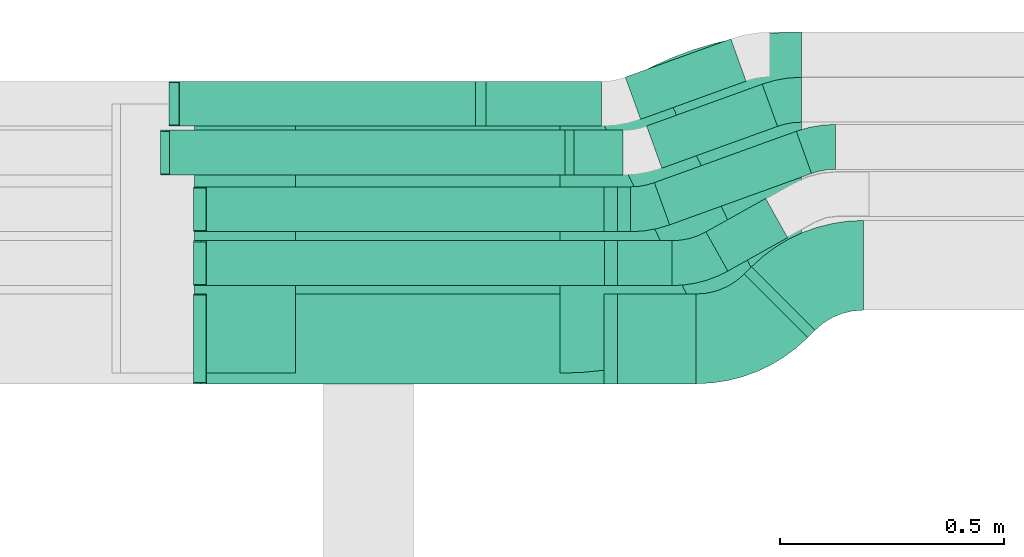
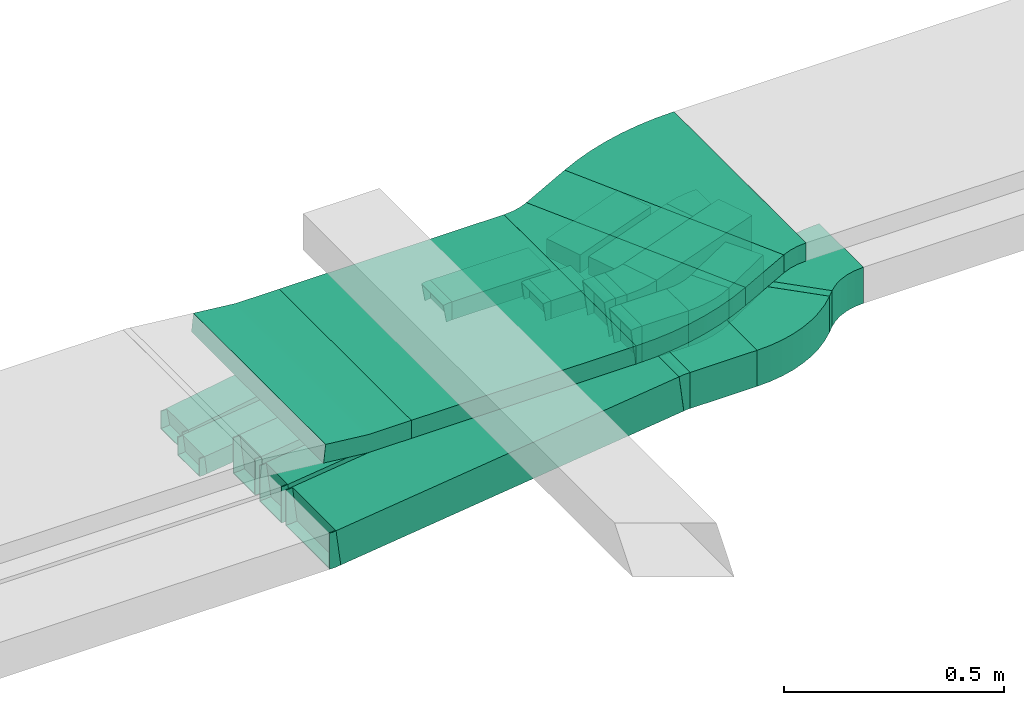
# One storey, part 18 of 28: 19 flow fittings, 17 flow segments.
"""IFC2X3 building model written with IfcOpenShell, lengths in millimetres."""

import ifcopenshell
import ifcopenshell.guid

model = None  # the IFC model being written
_history = None  # IfcOwnerHistory: only IFC2X3 demands one
_inside = {}  # id of a spatial element -> (the spatial element, [elements in it])
_under = {}  # id of a project, library or spatial element -> (it, [spatial elements below it])
_declared = {}  # id of a project -> (the project, [libraries it declares])
_typed = {}  # id of a type object -> (the type object, [elements of that type])
_made_of = {}  # id of a material, layer set ... -> (it, [elements and type objects made of it])


def new_model(schema):
    """Start an empty IFC model of exactly this schema.

    Asked for "IFC4X3", IfcOpenShell would pick the latest addendum, in which some entities
    have other attributes; the version numbers below select the first issue.
    IFC2X3 requires an IfcOwnerHistory on every rooted entity: one is made here for all.
    """
    global model, _history
    if schema == "IFC4X3":
        model = ifcopenshell.file(schema_version=(4, 3, 0, 0))
    else:
        model = ifcopenshell.file(schema=schema)
    _inside.clear()
    _under.clear()
    _declared.clear()
    _typed.clear()
    _made_of.clear()
    _history = None
    if model.schema == "IFC2X3":
        org = make("IfcOrganization", Name="unknown")
        user = make(
            "IfcPersonAndOrganization",
            ThePerson=make("IfcPerson", FamilyName="unknown"),
            TheOrganization=org,
        )
        app = make(
            "IfcApplication",
            ApplicationDeveloper=org,
            Version="unknown",
            ApplicationFullName="unknown",
            ApplicationIdentifier="unknown",
        )
        _history = make(
            "IfcOwnerHistory",
            OwningUser=user,
            OwningApplication=app,
            ChangeAction="ADDED",
            CreationDate=0,
        )
    return model


def make(cls, **values):
    """One entity of the class cls with the attributes given. An attribute that is None is left unset."""
    return model.create_entity(
        cls, **{name: value for name, value in values.items() if value is not None}
    )


def entity(cls, *values):
    """Any entity or typed value of the class cls, its attributes in the order of the schema. None: left unset."""
    e = model.create_entity(cls)
    for i, value in enumerate(values):
        if value is not None:
            e[i] = value
    return e


def rooted(cls, **values):
    """An entity with a GlobalId (a new one), such as an element, a storey or a relation."""
    return make(cls, GlobalId=ifcopenshell.guid.new(), OwnerHistory=_history, **values)


def si_unit(unit_type, name, prefix=None):
    """IfcSIUnit, for example si_unit("LENGTHUNIT", "METRE", prefix="MILLI")."""
    return make("IfcSIUnit", UnitType=unit_type, Prefix=prefix, Name=name)


def converted_unit(unit_type, name, factor, base, dimensions=None, offset=None):
    """IfcConversionBasedUnit, such as the inch: factor (a typed value) times the base unit."""
    return make(
        "IfcConversionBasedUnit"
        if offset is None
        else "IfcConversionBasedUnitWithOffset",
        ConversionOffset=offset,
        Dimensions=None
        if dimensions is None
        else entity("IfcDimensionalExponents", *dimensions),
        UnitType=unit_type,
        Name=name,
        ConversionFactor=make(
            "IfcMeasureWithUnit", ValueComponent=factor, UnitComponent=base
        ),
    )


def derived_unit(unit_type, elements):
    """IfcDerivedUnit: a product of units, each with its exponent."""
    return make(
        "IfcDerivedUnit",
        Elements=[
            make("IfcDerivedUnitElement", Unit=unit, Exponent=power)
            for unit, power in elements
        ],
        UnitType=unit_type,
    )


def assignment(units):
    """IfcUnitAssignment: the units of a project."""
    return None if units is None else make("IfcUnitAssignment", Units=units)


def point(xyz):
    """IfcCartesianPoint."""
    return None if xyz is None else make("IfcCartesianPoint", Coordinates=xyz)


def direction(xyz):
    """IfcDirection."""
    return None if xyz is None else make("IfcDirection", DirectionRatios=xyz)


def frame(location, z_axis=None, x_axis=None):
    """IfcAxis2Placement3D, a coordinate frame: its origin and axes. An axis left out is left unset."""
    return make(
        "IfcAxis2Placement3D",
        Location=point(location),
        Axis=direction(z_axis),
        RefDirection=direction(x_axis),
    )


def frame_2d(location, x_axis=None):
    """IfcAxis2Placement2D, a coordinate frame in the plane: its origin and x axis."""
    return make(
        "IfcAxis2Placement2D", Location=point(location), RefDirection=direction(x_axis)
    )


def origin():
    """The frame at (0, 0, 0) with its axes left unset."""
    return frame((0.0, 0.0, 0.0))


def origin_2d_with_axis():
    """The frame at (0, 0) in the plane with the x axis (1, 0) written out."""
    return frame_2d((0.0, 0.0), x_axis=(1.0, 0.0))


def place(relative_to, where):
    """IfcLocalPlacement: puts the frame where relative to a parent placement (None: the world)."""
    return make(
        "IfcLocalPlacement", PlacementRelTo=relative_to, RelativePlacement=where
    )


def context(
    kind, dimensions, precision=None, world=None, true_north=None, identifier=None
):
    """IfcGeometricRepresentationContext, for example the 3D "Model" context."""
    return make(
        "IfcGeometricRepresentationContext",
        ContextIdentifier=identifier,
        ContextType=kind,
        CoordinateSpaceDimension=dimensions,
        Precision=precision,
        WorldCoordinateSystem=world,
        TrueNorth=true_north,
    )


def subcontext(parent, identifier, kind, view, scale=None):
    """IfcGeometricRepresentationSubContext, for example "Body" below "Model"."""
    return make(
        "IfcGeometricRepresentationSubContext",
        ContextIdentifier=identifier,
        ContextType=kind,
        ParentContext=parent,
        TargetScale=scale,
        TargetView=view,
    )


def project(units=None, contexts=None):
    """IfcProject with its units and contexts."""
    return rooted(
        "IfcProject",
        Name="project",
        RepresentationContexts=contexts,
        UnitsInContext=assignment(units),
    )


def spatial(cls, under=None, at=None, **own):
    """A site, building, storey or space (cls), placed at a placement, below another one or the project."""
    s = rooted(cls, ObjectPlacement=at, **own)
    if under is not None:
        _under.setdefault(under.id(), (under, []))[1].append(s)
    return s


def polyline(points):
    """IfcPolyline through the points."""
    return make("IfcPolyline", Points=[point(p) for p in points])


def circle_curve(where, radius):
    """IfcCircle in the frame where."""
    return make("IfcCircle", Position=where, Radius=radius)


def parameter(value):
    """IfcParameterValue: where a trimmed curve begins or ends, as a parameter of its basis curve."""
    return model.create_entity("IfcParameterValue", value)


def trimmed(basis, trim1, trim2, sense, master):
    """IfcTrimmedCurve: the piece of a basis curve between two trims."""
    return make(
        "IfcTrimmedCurve",
        BasisCurve=basis,
        Trim1=trim1,
        Trim2=trim2,
        SenseAgreement=sense,
        MasterRepresentation=master,
    )


def segment(curve, same_sense, transition):
    """IfcCompositeCurveSegment."""
    return make(
        "IfcCompositeCurveSegment",
        Transition=transition,
        SameSense=same_sense,
        ParentCurve=curve,
    )


def composite_curve(segments, self_intersect=None):
    """IfcCompositeCurve: segments joined end to end."""
    return make("IfcCompositeCurve", Segments=segments, SelfIntersect=self_intersect)


def profile(cls, at=None, kind="AREA", **sizes):
    """A parametric profile (cls). Its sizes go by their IFC names, for example OverallWidth=200.0."""
    return make(cls, ProfileType=kind, Position=at, **sizes)


def rectangle(**sizes):
    """IfcRectangleProfileDef."""
    return profile("IfcRectangleProfileDef", **sizes)


def outline(outer, holes=None, kind="AREA"):
    """IfcArbitraryClosedProfileDef: a profile drawn as a closed curve; with holes, ...WithVoids."""
    if holes is None:
        return make("IfcArbitraryClosedProfileDef", ProfileType=kind, OuterCurve=outer)
    return make(
        "IfcArbitraryProfileDefWithVoids",
        ProfileType=kind,
        OuterCurve=outer,
        InnerCurves=holes,
    )


def extrude(swept, where, along, depth):
    """IfcExtrudedAreaSolid: the profile swept, set in the frame where, extruded along a direction by depth."""
    return make(
        "IfcExtrudedAreaSolid",
        SweptArea=swept,
        Position=where,
        ExtrudedDirection=direction(along),
        Depth=depth,
    )


def faces_of(points, faces, orient=None, outer=None):
    """IfcFace entities. A face is a list of loops; a loop is a list of indices into points, from 0.

    orient and outer hold one flag for each loop. By default every Orientation is true, the
    first loop of a face is its IfcFaceOuterBound and the others are IfcFaceBound.
    """
    made = []
    for i, loops in enumerate(faces):
        bounds = []
        for j, loop in enumerate(loops):
            is_outer = j == 0 if outer is None else outer[i][j]
            bounds.append(
                make(
                    "IfcFaceOuterBound" if is_outer else "IfcFaceBound",
                    Bound=make("IfcPolyLoop", Polygon=[points[k] for k in loop]),
                    Orientation=True if orient is None else orient[i][j],
                )
            )
        made.append(make("IfcFace", Bounds=bounds))
    return made


def faceted_brep(points, faces, orient=None, outer=None, voids=None):
    """IfcFacetedBrep: a solid bounded by flat faces; with voids (closed shells), ...WithVoids."""
    shared = [point(p) for p in points]
    hull = make("IfcClosedShell", CfsFaces=faces_of(shared, faces, orient, outer))
    if voids is None:
        return make("IfcFacetedBrep", Outer=hull)
    return make(
        "IfcFacetedBrepWithVoids",
        Outer=hull,
        Voids=[
            make(cls, CfsFaces=faces_of(shared, fs, o, b)) for cls, fs, o, b in voids
        ],
    )


def shape(context_of_items, identifier, shape_type, items):
    """IfcShapeRepresentation: the items that make up one representation, for example the "Body"."""
    return make(
        "IfcShapeRepresentation",
        ContextOfItems=context_of_items,
        RepresentationIdentifier=identifier,
        RepresentationType=shape_type,
        Items=items,
    )


def source(mapping_origin, context_of_items, identifier, shape_type, items):
    """IfcRepresentationMap: a shape defined once, which mapped items show again and again."""
    return make(
        "IfcRepresentationMap",
        MappingOrigin=mapping_origin,
        MappedRepresentation=shape(context_of_items, identifier, shape_type, items),
    )


def transform(
    local_origin,
    x_axis=None,
    y_axis=None,
    z_axis=None,
    scale=None,
    scale2=None,
    scale3=None,
    uniform=True,
):
    """IfcCartesianTransformationOperator3D, or its non-uniform kind. x_axis, y_axis, z_axis: its Axis1, 2, 3."""
    if uniform:
        return make(
            "IfcCartesianTransformationOperator3D",
            Axis1=direction(x_axis),
            Axis2=direction(y_axis),
            LocalOrigin=point(local_origin),
            Scale=scale,
            Axis3=direction(z_axis),
        )
    return make(
        "IfcCartesianTransformationOperator3DnonUniform",
        Axis1=direction(x_axis),
        Axis2=direction(y_axis),
        LocalOrigin=point(local_origin),
        Scale=scale,
        Axis3=direction(z_axis),
        Scale2=scale2,
        Scale3=scale3,
    )


def mapped(mapping_source, mapping_target):
    """IfcMappedItem: shows the shape of a source again, moved by a transform."""
    return make(
        "IfcMappedItem", MappingSource=mapping_source, MappingTarget=mapping_target
    )


def material(Name=None, Category=None):
    """IfcMaterial."""
    return make("IfcMaterial", Name=Name, Category=Category)


def made_of(thing, what):
    """Note that an element or type object is made of a material, layer set ...; save() writes the relation."""
    if what is not None:
        _made_of.setdefault(what.id(), (what, []))[1].append(thing)
    return thing


def type_object(cls, material=None, **own):
    """A type object (cls), such as IfcWallType, which elements share."""
    return made_of(rooted(cls, **own), material)


def type_shapes(of_type, sources):
    """Give a type object the sources (RepresentationMaps) that its elements show as mapped items."""
    of_type.RepresentationMaps = sources


def element(
    cls,
    number,
    at=None,
    inside=None,
    cuts=None,
    type_object=None,
    material=None,
    context=None,
    identifier="Body",
    shape_type=None,
    held_by="IfcProductDefinitionShape",
    body=None,
    shapes=None,
    **own,
):
    """One element of the class cls, such as IfcWall. Its Tag is "e" and its number.

    at: its placement. inside: the storey or other place that contains it. cuts: it is an
    opening in that element (IfcRelVoidsElement). A single representation is given by context,
    identifier, shape_type and body (its items); several are given by shapes. held_by: the class
    of the entity that holds the representations. save() writes the other relations.
    """
    e = rooted(cls, Tag="e%d" % number, ObjectPlacement=at, **own)
    if body is not None:
        shapes = [shape(context, identifier, shape_type, body)]
    if shapes is not None:
        e.Representation = make(held_by, Representations=shapes)
    if inside is not None:
        _inside.setdefault(inside.id(), (inside, []))[1].append(e)
    if cuts is not None:
        rooted(
            "IfcRelVoidsElement", RelatingBuildingElement=cuts, RelatedOpeningElement=e
        )
    if type_object is not None:
        _typed.setdefault(type_object.id(), (type_object, []))[1].append(e)
    return made_of(e, material)


def aggregate(whole, parts):
    """IfcRelAggregates: a whole, such as a stair, and the parts it consists of."""
    return rooted("IfcRelAggregates", RelatingObject=whole, RelatedObjects=parts)


def save(model, path):
    """Write the relations noted so far, then the file.

    IfcRelAggregates (storeys below a building ...), IfcRelContainedInSpatialStructure (elements
    in a storey), IfcRelDefinesByType, IfcRelAssociatesMaterial and IfcRelDeclares: one each for
    every whole, place, type object, material and project.
    """
    for whole, parts in _under.values():
        aggregate(whole, parts)
    for where, things in _inside.values():
        rooted(
            "IfcRelContainedInSpatialStructure",
            RelatedElements=things,
            RelatingStructure=where,
        )
    for kind, things in _typed.values():
        rooted("IfcRelDefinesByType", RelatedObjects=things, RelatingType=kind)
    for what, things in _made_of.values():
        rooted("IfcRelAssociatesMaterial", RelatedObjects=things, RelatingMaterial=what)
    for by, libraries in _declared.values():
        rooted("IfcRelDeclares", RelatingContext=by, RelatedDefinitions=libraries)
    model.write(path)


model = new_model("IFC2X3")

# Units and contexts
model_context = context("Model", 3, precision=0.01, world=origin(), true_north=direction((6.12303176911189e-17, 1.0)))
body_context = subcontext(model_context, "Body", "Model", "MODEL_VIEW")
ifc_project = project(units=[si_unit("LENGTHUNIT", "METRE", prefix="MILLI"), si_unit("AREAUNIT", "SQUARE_METRE"), si_unit("VOLUMEUNIT", "CUBIC_METRE"), converted_unit("PLANEANGLEUNIT", "DEGREE", entity("IfcRatioMeasure", 0.0174532925199433), si_unit("PLANEANGLEUNIT", "RADIAN"), dimensions=[0, 0, 0, 0, 0, 0, 0]), si_unit("MASSUNIT", "GRAM", prefix="KILO"), derived_unit("MASSDENSITYUNIT", [(si_unit("MASSUNIT", "GRAM", prefix="KILO"), 1), (si_unit("LENGTHUNIT", "METRE"), -3)]), derived_unit("MOMENTOFINERTIAUNIT", [(si_unit("LENGTHUNIT", "METRE"), 4)]), si_unit("TIMEUNIT", "SECOND"), si_unit("FREQUENCYUNIT", "HERTZ"), si_unit("THERMODYNAMICTEMPERATUREUNIT", "DEGREE_CELSIUS"), derived_unit("THERMALTRANSMITTANCEUNIT", [(si_unit("MASSUNIT", "GRAM", prefix="KILO"), 1), (si_unit("THERMODYNAMICTEMPERATUREUNIT", "KELVIN"), -1), (si_unit("TIMEUNIT", "SECOND"), -3)]), derived_unit("VOLUMETRICFLOWRATEUNIT", [(si_unit("LENGTHUNIT", "METRE"), 3), (si_unit("TIMEUNIT", "SECOND"), -1)]), derived_unit("MASSFLOWRATEUNIT", [(si_unit("MASSUNIT", "GRAM", prefix="KILO"), 1), (si_unit("TIMEUNIT", "SECOND"), -1)]), derived_unit("ROTATIONALFREQUENCYUNIT", [(si_unit("TIMEUNIT", "SECOND"), -1)]), si_unit("ELECTRICCURRENTUNIT", "AMPERE"), si_unit("ELECTRICVOLTAGEUNIT", "VOLT"), si_unit("POWERUNIT", "WATT"), si_unit("FORCEUNIT", "NEWTON", prefix="KILO"), si_unit("ILLUMINANCEUNIT", "LUX"), si_unit("LUMINOUSFLUXUNIT", "LUMEN"), si_unit("LUMINOUSINTENSITYUNIT", "CANDELA"), derived_unit("USERDEFINED", [(si_unit("MASSUNIT", "GRAM", prefix="KILO"), -1), (si_unit("LENGTHUNIT", "METRE"), -2), (si_unit("TIMEUNIT", "SECOND"), 3), (si_unit("LUMINOUSFLUXUNIT", "LUMEN"), 1)]), derived_unit("LINEARVELOCITYUNIT", [(si_unit("LENGTHUNIT", "METRE"), 1), (si_unit("TIMEUNIT", "SECOND"), -1)]), si_unit("PRESSUREUNIT", "PASCAL"), derived_unit("USERDEFINED", [(si_unit("LENGTHUNIT", "METRE"), -2), (si_unit("MASSUNIT", "GRAM", prefix="KILO"), 1), (si_unit("TIMEUNIT", "SECOND"), -2)]), derived_unit("LINEARFORCEUNIT", [(si_unit("MASSUNIT", "GRAM", prefix="KILO"), 1), (si_unit("LENGTHUNIT", "METRE"), 1), (si_unit("TIMEUNIT", "SECOND"), -2), (si_unit("LENGTHUNIT", "METRE"), -1)]), derived_unit("PLANARFORCEUNIT", [(si_unit("MASSUNIT", "GRAM", prefix="KILO"), 1), (si_unit("LENGTHUNIT", "METRE"), 1), (si_unit("TIMEUNIT", "SECOND"), -2), (si_unit("LENGTHUNIT", "METRE"), -2)])], contexts=[model_context])

# Site, building, storey
site_placement = place(None, origin())
site = spatial("IfcSite", under=ifc_project, at=site_placement, CompositionType="ELEMENT")
building_placement = place(site_placement, origin())
building = spatial("IfcBuilding", under=site, at=building_placement, CompositionType="ELEMENT")
storey_placement = place(building_placement, frame((0.0, 0.0, 4200.0)))
storey = spatial("IfcBuildingStorey", under=building, at=storey_placement, CompositionType="ELEMENT", Elevation=4200.0)

# Flow segments
cable_carrier_segment_type = type_object("IfcCableCarrierSegmentType", PredefinedType="CABLETRAYSEGMENT")
flow_segment_1_placement = place(storey_placement, frame((26151.95, 15455.69, 2793.21)))
element("IfcFlowSegment", 1, at=flow_segment_1_placement, inside=storey, type_object=cable_carrier_segment_type, context=body_context, shape_type="SweptSolid", body=[
    extrude(rectangle(XDim=155.206153219677, YDim=600.0, at=origin_2d_with_axis()), frame((201.26, 303.66, 0.0), z_axis=(0.0, 0.0, 1.0), x_axis=(-0.898794046299167, -0.438371146789078, 0.0)), (0.0, 0.0, 1.0), 49.9999999999995),
])
flow_segment_2_placement = place(storey_placement, frame((25495.24, 15379.35, 2793.21)))
element("IfcFlowSegment", 2, at=flow_segment_2_placement, inside=storey, type_object=cable_carrier_segment_type, context=body_context, shape_type="SweptSolid", body=[
    extrude(rectangle(XDim=589.05051708577, YDim=599.999999999998, at=origin_2d_with_axis()), frame((294.53, 300.0, 0.0), z_axis=(0.0, 0.0, 1.0), x_axis=(-1.0, 0.0, 0.0)), (0.0, 0.0, 1.0), 49.9999999999995),
])
flow_segment_3_placement = place(storey_placement, frame((26495.49, 15458.88, 2639.21)))
element("IfcFlowSegment", 3, at=flow_segment_3_placement, inside=storey, type_object=cable_carrier_segment_type, context=body_context, shape_type="SweptSolid", body=[
    extrude(rectangle(XDim=22.5844049492806, YDim=199.999999999995, at=origin_2d_with_axis()), frame((78.7, 78.7, 0.0), z_axis=(0.0, 0.0, 1.0), x_axis=(-0.707106781186596, -0.7071067811865, 0.0)), (0.0, 0.0, 1.0), 99.9999999999989),
])
flow_segment_4_placement = place(storey_placement, frame((26212.27, 15355.66, 2639.21)))
element("IfcFlowSegment", 4, at=flow_segment_4_placement, inside=storey, type_object=cable_carrier_segment_type, context=body_context, shape_type="SweptSolid", body=[
    extrude(rectangle(XDim=175.445612052065, YDim=200.000000000002, at=origin_2d_with_axis()), frame((87.72, 100.0, 0.0), z_axis=(0.0, 0.0, 1.0), x_axis=(-1.0, 0.0, 0.0)), (0.0, 0.0, 1.0), 99.9999999999989),
])
flow_segment_5_placement = place(storey_placement, frame((25284.24, 15355.66, 2526.3)))
element("IfcFlowSegment", 5, at=flow_segment_5_placement, inside=storey, type_object=cable_carrier_segment_type, context=body_context, shape_type="SweptSolid", body=[
    extrude(rectangle(XDim=99.9999999999987, YDim=200.000000000002, at=frame_2d((0.0, 0.0), x_axis=(0.0, 1.0))), frame((6.17, 100.0, 49.62), z_axis=(0.992344783104405, 0.0, 0.123498305435627), x_axis=(0.0, 1.0, 0.0)), (0.0, 0.0, 1.0), 905.864321564183),
])
flow_segment_6_placement = place(storey_placement, frame((26212.8, 15574.48, 2634.95)))
element("IfcFlowSegment", 6, at=flow_segment_6_placement, inside=storey, type_object=cable_carrier_segment_type, context=body_context, shape_type="SweptSolid", body=[
    extrude(rectangle(XDim=121.812997004483, YDim=99.9999999999989, at=origin_2d_with_axis()), frame((60.91, 50.0, 0.0), z_axis=(0.0, 0.0, 1.0), x_axis=(-1.0, 0.0, 0.0)), (0.0, 0.0, 1.0), 99.9999999999989),
])
flow_segment_7_placement = place(storey_placement, frame((25284.24, 15574.48, 2521.97)))
element("IfcFlowSegment", 7, at=flow_segment_7_placement, inside=storey, type_object=cable_carrier_segment_type, context=body_context, shape_type="SweptSolid", body=[
    extrude(rectangle(XDim=99.9999999999987, YDim=99.9999999999989, at=frame_2d((0.0, 0.0), x_axis=(0.0, 1.0))), frame((6.17, 50.0, 49.62), z_axis=(0.992344783104405, 0.0, 0.123498305435627), x_axis=(0.0, 1.0, 0.0)), (0.0, 0.0, 1.0), 906.398619593453),
])
flow_segment_8_placement = place(storey_placement, frame((26409.68, 15606.74, 2634.95)))
element("IfcFlowSegment", 8, at=flow_segment_8_placement, inside=storey, type_object=cable_carrier_segment_type, context=body_context, shape_type="SweptSolid", body=[
    extrude(rectangle(XDim=152.623669799457, YDim=99.9999999999999, at=origin_2d_with_axis()), frame((91.01, 80.88, 0.0), z_axis=(0.0, 0.0, 1.0), x_axis=(0.87289325109934, 0.487911233919884, 0.0)), (0.0, 0.0, 1.0), 99.9999999999989),
])
flow_segment_9_placement = place(storey_placement, frame((26212.27, 15694.48, 2639.21)))
element("IfcFlowSegment", 9, at=flow_segment_9_placement, inside=storey, type_object=cable_carrier_segment_type, context=body_context, shape_type="SweptSolid", body=[
    extrude(rectangle(XDim=29.5976142987202, YDim=99.9999999999989, at=origin_2d_with_axis()), frame((14.8, 50.0, 0.0), z_axis=(0.0, 0.0, 1.0), x_axis=(-1.0, 0.0, 0.0)), (0.0, 0.0, 1.0), 99.9999999999989),
])
flow_segment_10_placement = place(storey_placement, frame((25284.24, 15694.48, 2526.3)))
element("IfcFlowSegment", 10, at=flow_segment_10_placement, inside=storey, type_object=cable_carrier_segment_type, context=body_context, shape_type="SweptSolid", body=[
    extrude(rectangle(XDim=100.000000000001, YDim=99.9999999999989, at=frame_2d((0.0, 0.0), x_axis=(0.0, 1.0))), frame((6.17, 50.0, 49.62), z_axis=(0.992344783104405, 0.0, 0.123498305435624), x_axis=(0.0, 1.0, 0.0)), (0.0, 0.0, 1.0), 905.864321564186),
])
flow_segment_11_placement = place(storey_placement, frame((26294.84, 15709.73, 2639.21)))
element("IfcFlowSegment", 11, at=flow_segment_11_placement, inside=storey, type_object=cable_carrier_segment_type, context=body_context, shape_type="SweptSolid", body=[
    extrude(rectangle(XDim=336.229812926671, YDim=100.000000000002, at=origin_2d_with_axis()), frame((175.1, 104.21, 0.0), z_axis=(0.0, 0.0, 1.0), x_axis=(0.940342650313565, 0.340228893542658, 0.0)), (0.0, 0.0, 1.0), 99.9999999999989),
])
flow_segment_12_placement = place(storey_placement, frame((26277.55, 15835.92, 2639.21)))
element("IfcFlowSegment", 12, at=flow_segment_12_placement, inside=storey, type_object=cable_carrier_segment_type, context=body_context, shape_type="SweptSolid", body=[
    extrude(rectangle(XDim=273.962798043849, YDim=99.9999999999994, at=origin_2d_with_axis()), frame((145.82, 93.62, 0.0), z_axis=(0.0, 0.0, 1.0), x_axis=(-0.940342650313538, -0.340228893542731, 0.0)), (0.0, 0.0, 1.0), 49.9999999999994),
])
flow_segment_13_placement = place(storey_placement, frame((26115.8, 15820.66, 2639.21)))
element("IfcFlowSegment", 13, at=flow_segment_13_placement, inside=storey, type_object=cable_carrier_segment_type, context=body_context, shape_type="SweptSolid", body=[
    extrude(rectangle(XDim=108.780385124798, YDim=99.9999999999989, at=origin_2d_with_axis()), frame((54.39, 50.0, 0.0), z_axis=(0.0, 0.0, 1.0), x_axis=(-1.0, 0.0, 0.0)), (0.0, 0.0, 1.0), 50.0000000000005),
])
flow_segment_14_placement = place(storey_placement, frame((25208.33, 15820.66, 2525.76)))
element("IfcFlowSegment", 14, at=flow_segment_14_placement, inside=storey, type_object=cable_carrier_segment_type, context=body_context, shape_type="SweptSolid", body=[
    extrude(rectangle(XDim=49.9999999999989, YDim=99.9999999999989, at=frame_2d((0.0, 0.0), x_axis=(0.0, 1.0))), frame((3.15, 50.0, 24.8), z_axis=(0.992048888386648, 0.0, 0.125853101077474), x_axis=(0.0, 1.0, 0.0)), (0.0, 0.0, 1.0), 894.551926158858),
])
flow_segment_15_placement = place(storey_placement, frame((26230.12, 15944.84, 2639.21)))
element("IfcFlowSegment", 15, at=flow_segment_15_placement, inside=storey, type_object=cable_carrier_segment_type, context=body_context, shape_type="SweptSolid", body=[
    extrude(rectangle(XDim=249.969549978698, YDim=99.9999999999994, at=origin_2d_with_axis()), frame((134.54, 89.54, 0.0), z_axis=(0.0, 0.0, 1.0), x_axis=(-0.940342650313534, -0.340228893542741, 0.0)), (0.0, 0.0, 1.0), 49.9999999999995),
])
flow_segment_16_placement = place(storey_placement, frame((25919.8, 15929.59, 2639.21)))
element("IfcFlowSegment", 16, at=flow_segment_16_placement, inside=storey, type_object=cable_carrier_segment_type, context=body_context, shape_type="SweptSolid", body=[
    extrude(rectangle(XDim=257.337712334829, YDim=99.9999999999989, at=origin_2d_with_axis()), frame((128.67, 50.0, 0.0), z_axis=(0.0, 0.0, 1.0), x_axis=(-1.0, 0.0, 0.0)), (0.0, 0.0, 1.0), 49.9999999999995),
])
flow_segment_17_placement = place(storey_placement, frame((25228.38, 15929.59, 2526.41)))
element("IfcFlowSegment", 17, at=flow_segment_17_placement, inside=storey, type_object=cable_carrier_segment_type, context=body_context, shape_type="SweptSolid", body=[
    extrude(rectangle(XDim=50.0000000000004, YDim=99.9999999999989, at=frame_2d((0.0, 0.0), x_axis=(0.0, 1.0))), frame((4.12, 50.0, 24.66), z_axis=(0.986350532823018, 0.0, 0.16465912182369), x_axis=(0.0, 1.0, 0.0)), (0.0, 0.0, 1.0), 677.56498046901),
])

# Flow fittings
ifc_material = material()
cable_carrier_fitting_type_1 = type_object("IfcCableCarrierFittingType", PredefinedType="NOTDEFINED", material=ifc_material)
shared_shape_1 = source(origin(), body_context, "Body", "Brep", [
    faceted_brep([(-11.51, -50.0, 100.0), (-11.51, 50.0, 100.0), (-11.51, 50.0, 97.46), (-11.51, -47.46, 97.46), (-11.51, -47.46, -97.46), (-11.51, 50.0, -97.46), (-11.51, 50.0, -100.0), (-11.51, -50.0, -100.0), (17.6, -48.2, 100.0), (17.6, -48.2, -100.0), (5.25, 51.04, -100.0), (5.25, 51.04, -97.46), (17.28, -45.68, -97.46), (17.28, -45.68, 97.46), (5.25, 51.04, 97.46), (5.25, 51.04, 100.0), (3.1, -50.0, 100.0), (-3.1, 50.0, 100.0), (-3.1, 50.0, 97.46), (2.94, -47.46, 97.46), (2.94, -47.46, -97.46), (-3.1, 50.0, -97.46), (-3.1, 50.0, -100.0), (3.1, -50.0, -100.0)], [[[0, 1, 2, 3, 4, 5, 6, 7]], [[8, 9, 10, 11, 12, 13, 14, 15]], [[1, 0, 16, 8, 15, 17]], [[2, 1, 17, 18]], [[3, 2, 18, 14, 13, 19]], [[4, 3, 19, 20]], [[5, 4, 20, 12, 11, 21]], [[6, 5, 21, 22]], [[7, 6, 22, 10, 9, 23]], [[0, 7, 23, 16]], [[18, 17, 15, 14]], [[20, 19, 13, 12]], [[22, 21, 11, 10]], [[16, 23, 9, 8]]]),
])
type_shapes(cable_carrier_fitting_type_1, [shared_shape_1])
for number, where, z_axis, x_axis in (
    (18, (25278.99, 15455.66, 2574.49), (0.0, -1.0, 0.0), (1.0, 0.0, 0.0)),
    (19, (26200.76, 15455.66, 2689.21), (0.0, -1.0, 0.0), (-1.0, 0.0, 0.0)),
):
    element("IfcFlowFitting", number, at=place(storey_placement, frame(where, z_axis=z_axis, x_axis=x_axis)), inside=storey, type_object=cable_carrier_fitting_type_1, material=ifc_material, context=body_context, shape_type="MappedRepresentation", body=[
        mapped(shared_shape_1, transform((0.0, 0.0, 0.0), scale=1.0)),
    ])
cable_carrier_fitting_type_2 = type_object("IfcCableCarrierFittingType", PredefinedType="NOTDEFINED", material=ifc_material)
shared_shape_2 = source(origin(), body_context, "Body", "Brep", [
    faceted_brep([(-11.51, -50.0, 50.0), (-11.51, 50.0, 50.0), (-11.51, 50.0, 47.46), (-11.51, -47.46, 47.46), (-11.51, -47.46, -47.46), (-11.51, 50.0, -47.46), (-11.51, 50.0, -50.0), (-11.51, -50.0, -50.0), (17.6, -48.2, 50.0), (17.6, -48.2, -50.0), (5.25, 51.04, -50.0), (5.25, 51.04, -47.46), (17.28, -45.68, -47.46), (17.28, -45.68, 47.46), (5.25, 51.04, 47.46), (5.25, 51.04, 50.0), (3.1, -50.0, 50.0), (-3.1, 50.0, 50.0), (-3.1, 50.0, 47.46), (2.94, -47.46, 47.46), (2.94, -47.46, -47.46), (-3.1, 50.0, -47.46), (-3.1, 50.0, -50.0), (3.1, -50.0, -50.0)], [[[0, 1, 2, 3, 4, 5, 6, 7]], [[8, 9, 10, 11, 12, 13, 14, 15]], [[1, 0, 16, 8, 15, 17]], [[2, 1, 17, 18]], [[3, 2, 18, 14, 13, 19]], [[4, 3, 19, 20]], [[5, 4, 20, 12, 11, 21]], [[6, 5, 21, 22]], [[7, 6, 22, 10, 9, 23]], [[0, 7, 23, 16]], [[18, 17, 15, 14]], [[20, 19, 13, 12]], [[22, 21, 11, 10]], [[16, 23, 9, 8]]]),
])
type_shapes(cable_carrier_fitting_type_2, [shared_shape_2])
for number, where, z_axis, x_axis in (
    (20, (26201.29, 15624.48, 2684.95), (0.0, -1.0, 0.0), (-1.0, 0.0, 0.0)),
    (21, (26200.76, 15744.48, 2689.21), (0.0, -1.0, 0.0), (-1.0, 0.0, 0.0)),
    (22, (25278.99, 15624.48, 2570.16), (0.0, 1.0, 0.0), (-0.992344783104403, 0.0, -0.123498305435642)),
    (23, (25278.99, 15744.48, 2574.49), (0.0, 1.0, 0.0), (-0.992344783104403, 0.0, -0.123498305435642)),
):
    element("IfcFlowFitting", number, at=place(storey_placement, frame(where, z_axis=z_axis, x_axis=x_axis)), inside=storey, type_object=cable_carrier_fitting_type_2, material=ifc_material, context=body_context, shape_type="MappedRepresentation", body=[
        mapped(shared_shape_2, transform((0.0, 0.0, 0.0), scale=1.0)),
    ])
cable_carrier_fitting_type_3 = type_object("IfcCableCarrierFittingType", PredefinedType="NOTDEFINED", material=ifc_material)
shared_shape_3 = source(origin(), body_context, "Body", "Brep", [
    faceted_brep([(-8.47, -25.0, 50.0), (-8.47, 25.0, 50.0), (-8.47, 25.0, 47.46), (-8.47, -22.46, 47.46), (-8.47, -22.46, -47.46), (-8.47, 25.0, -47.46), (-8.47, 25.0, -50.0), (-8.47, -25.0, -50.0), (11.55, -23.73, 50.0), (11.55, -23.73, -50.0), (5.26, 25.87, -50.0), (5.26, 25.87, -47.46), (11.23, -21.21, -47.46), (11.23, -21.21, 47.46), (5.26, 25.87, 47.46), (5.26, 25.87, 50.0), (1.58, -25.0, 50.0), (-1.58, 25.0, 50.0), (-1.58, 25.0, 47.46), (1.42, -22.46, 47.46), (1.42, -22.46, -47.46), (-1.58, 25.0, -47.46), (-1.58, 25.0, -50.0), (1.58, -25.0, -50.0)], [[[0, 1, 2, 3, 4, 5, 6, 7]], [[8, 9, 10, 11, 12, 13, 14, 15]], [[1, 0, 16, 8, 15, 17]], [[2, 1, 17, 18]], [[3, 2, 18, 14, 13, 19]], [[4, 3, 19, 20]], [[5, 4, 20, 12, 11, 21]], [[6, 5, 21, 22]], [[7, 6, 22, 10, 9, 23]], [[0, 7, 23, 16]], [[18, 17, 15, 14]], [[20, 19, 13, 12]], [[22, 21, 11, 10]], [[16, 23, 9, 8]]]),
])
type_shapes(cable_carrier_fitting_type_3, [shared_shape_3])
for number, where, z_axis, x_axis in (
    (24, (25203.07, 15870.66, 2549.49), (0.0, -1.0, 0.0), (1.0, 0.0, 0.0)),
    (25, (26107.32, 15870.66, 2664.21), (0.0, -1.0, 0.0), (-1.0, 0.0, 0.0)),
):
    element("IfcFlowFitting", number, at=place(storey_placement, frame(where, z_axis=z_axis, x_axis=x_axis)), inside=storey, type_object=cable_carrier_fitting_type_3, material=ifc_material, context=body_context, shape_type="MappedRepresentation", body=[
        mapped(shared_shape_3, transform((0.0, 0.0, 0.0), scale=1.0)),
    ])
cable_carrier_fitting_type_4 = type_object("IfcCableCarrierFittingType", PredefinedType="NOTDEFINED", material=ifc_material)
shared_shape_4 = source(origin(), body_context, "Body", "Brep", [
    faceted_brep([(-9.56, -25.0, 50.0), (-9.56, 25.0, 50.0), (-9.56, 25.0, 47.46), (-9.56, -22.46, 47.46), (-9.56, -22.46, -47.46), (-9.56, 25.0, -47.46), (-9.56, 25.0, -50.0), (-9.56, -25.0, -50.0), (13.55, -23.08, 50.0), (13.55, -23.08, -50.0), (5.31, 26.23, -50.0), (5.31, 26.23, -47.46), (13.13, -20.58, -47.46), (13.13, -20.58, 47.46), (5.31, 26.23, 47.46), (5.31, 26.23, 50.0), (2.07, -25.0, 50.0), (-2.07, 25.0, 50.0), (-2.07, 25.0, 47.46), (1.86, -22.46, 47.46), (1.86, -22.46, -47.46), (-2.07, 25.0, -47.46), (-2.07, 25.0, -50.0), (2.07, -25.0, -50.0)], [[[0, 1, 2, 3, 4, 5, 6, 7]], [[8, 9, 10, 11, 12, 13, 14, 15]], [[1, 0, 16, 8, 15, 17]], [[2, 1, 17, 18]], [[3, 2, 18, 14, 13, 19]], [[4, 3, 19, 20]], [[5, 4, 20, 12, 11, 21]], [[6, 5, 21, 22]], [[7, 6, 22, 10, 9, 23]], [[0, 7, 23, 16]], [[18, 17, 15, 14]], [[20, 19, 13, 12]], [[22, 21, 11, 10]], [[16, 23, 9, 8]]]),
])
type_shapes(cable_carrier_fitting_type_4, [shared_shape_4])
for number, where, z_axis, x_axis in (
    (26, (25223.07, 15979.59, 2549.49), (0.0, -1.0, 0.0), (1.0, 0.0, 0.0)),
    (27, (25910.24, 15979.59, 2664.21), (0.0, 1.0, 0.0), (0.986350532823018, 0.0, 0.164659121823689)),
):
    element("IfcFlowFitting", number, at=place(storey_placement, frame(where, z_axis=z_axis, x_axis=x_axis)), inside=storey, type_object=cable_carrier_fitting_type_4, material=ifc_material, context=body_context, shape_type="MappedRepresentation", body=[
        mapped(shared_shape_4, transform((0.0, 0.0, 0.0), scale=1.0)),
    ])
cable_carrier_fitting_type_5 = type_object("IfcCableCarrierFittingType", Name="470_DKC_S5_Variable Angle Elbow 0-45:-", PredefinedType="NOTDEFINED", material=ifc_material)
shared_shape_5 = source(origin(), body_context, "Body", "SweptSolid", [
    extrude(outline(composite_curve([segment(polyline([(-99.61, -322.88), (-98.61, -322.88)]), True, "CONTINUOUS"), segment(trimmed(circle_curve(frame_2d((-98.61, 427.12), x_axis=(0.0, -1.0)), 750.0), [parameter(0.0)], [parameter(26.0)], True, "PARAMETER"), True, "CONTINUOUS"), segment(polyline([(230.17, -246.98), (231.07, -246.54)]), True, "CONTINUOUS"), segment(polyline([(231.07, -246.54), (-31.95, 292.74)]), True, "CONTINUOUS"), segment(polyline([(-31.95, 292.74), (-32.85, 292.3)]), True, "CONTINUOUS"), segment(trimmed(circle_curve(frame_2d((-98.61, 427.12), x_axis=(0.0, -1.0)), 150.0), [parameter(0.0)], [parameter(26.0)], True, "PARAMETER"), False, "CONTINUOUS"), segment(polyline([(-98.61, 277.12), (-99.61, 277.12)]), True, "CONTINUOUS"), segment(polyline([(-99.61, 277.12), (-99.61, -322.88)]), True, "CONTINUOUS")], self_intersect=False)), frame((-5.28, 22.88, -25.0)), (0.0, 0.0, 1.0), 50.0000000000037),
])
type_shapes(cable_carrier_fitting_type_5, [shared_shape_5])
flow_fitting_1_placement = place(storey_placement, frame((26189.19, 15679.35, 2818.21)))
element("IfcFlowFitting", 28, at=flow_fitting_1_placement, inside=storey, type_object=cable_carrier_fitting_type_5, material=ifc_material, Name="470_DKC_S5_Variable Angle Elbow 0-45:-", ObjectType="470_DKC_S5_Variable Angle Elbow 0-45:-", context=body_context, shape_type="MappedRepresentation", body=[
    mapped(shared_shape_5, transform((0.0, 0.0, 0.0), scale=1.0)),
])
flow_fitting_2_placement = place(storey_placement, frame((26517.23, 15839.35, 2818.21), z_axis=(0.0, 0.0, 1.0), x_axis=(-1.0, 0.0, 0.0)))
element("IfcFlowFitting", 29, at=flow_fitting_2_placement, inside=storey, type_object=cable_carrier_fitting_type_5, material=ifc_material, Name="470_DKC_S5_Variable Angle Elbow 0-45:-", ObjectType="470_DKC_S5_Variable Angle Elbow 0-45:-", context=body_context, shape_type="MappedRepresentation", body=[
    mapped(shared_shape_5, transform((0.0, 0.0, 0.0), scale=1.0)),
])
cable_carrier_fitting_type_6 = type_object("IfcCableCarrierFittingType", Name="470_DKC_S5_CD 90 external vertical angle:-", PredefinedType="NOTDEFINED", material=ifc_material)
shared_shape_6 = source(origin(), body_context, "Body", "SweptSolid", [
    extrude(outline(composite_curve([segment(polyline([(-113.83, -28.22), (-8.52, -28.22)]), True, "CONTINUOUS"), segment(trimmed(circle_curve(frame_2d((-8.52, 161.78), x_axis=(0.0, -1.0)), 189.999999999999), [parameter(0.0)], [parameter(6.0298424485104)], True, "PARAMETER"), True, "CONTINUOUS"), segment(polyline([(11.44, -27.17), (116.17, -16.11)]), True, "CONTINUOUS"), segment(polyline([(116.17, -16.11), (110.92, 33.62)]), True, "CONTINUOUS"), segment(polyline([(110.92, 33.62), (6.19, 22.55)]), True, "CONTINUOUS"), segment(trimmed(circle_curve(frame_2d((-8.52, 161.78), x_axis=(0.0, -1.0)), 139.999999999999), [parameter(0.0)], [parameter(6.0298424485104)], True, "PARAMETER"), False, "CONTINUOUS"), segment(polyline([(-8.52, 21.78), (-113.83, 21.78)]), True, "CONTINUOUS"), segment(polyline([(-113.83, 21.78), (-113.83, -28.22)]), True, "CONTINUOUS")], self_intersect=False)), frame((-0.17, 3.22, -300.0)), (0.0, 0.0, 1.0), 600.0),
])
type_shapes(cable_carrier_fitting_type_6, [shared_shape_6])
flow_fitting_3_placement = place(storey_placement, frame((25381.24, 15679.35, 2818.21), z_axis=(0.0, -1.0, 0.0), x_axis=(0.994467316928114, 0.0, -0.105046444784187)))
element("IfcFlowFitting", 30, at=flow_fitting_3_placement, inside=storey, type_object=cable_carrier_fitting_type_6, material=ifc_material, Name="470_DKC_S5_CD 90 external vertical angle:-", ObjectType="470_DKC_S5_CD 90 external vertical angle:-", context=body_context, shape_type="MappedRepresentation", body=[
    mapped(shared_shape_6, transform((0.0, 0.0, 0.0), scale=1.0)),
])
cable_carrier_fitting_type_7 = type_object("IfcCableCarrierFittingType", Name="470_DKC_S5_Variable Angle Elbow 0-45:-", PredefinedType="NOTDEFINED", material=ifc_material)
shared_shape_7 = source(origin(), body_context, "Body", "SweptSolid", [
    extrude(outline(composite_curve([segment(polyline([(-89.32, -136.79), (-88.32, -136.79)]), True, "CONTINUOUS"), segment(trimmed(circle_curve(frame_2d((-88.32, 213.21), x_axis=(0.0, -1.0)), 350.0), [parameter(0.0)], [parameter(45.0)], True, "PARAMETER"), True, "CONTINUOUS"), segment(polyline([(159.17, -34.28), (159.88, -33.57)]), True, "CONTINUOUS"), segment(polyline([(159.88, -33.57), (18.46, 107.85)]), True, "CONTINUOUS"), segment(polyline([(18.46, 107.85), (17.75, 107.15)]), True, "CONTINUOUS"), segment(trimmed(circle_curve(frame_2d((-88.32, 213.21), x_axis=(0.0, -1.0)), 150.0), [parameter(0.0)], [parameter(45.0)], True, "PARAMETER"), False, "CONTINUOUS"), segment(polyline([(-88.32, 63.21), (-89.32, 63.21)]), True, "CONTINUOUS"), segment(polyline([(-89.32, 63.21), (-89.32, -136.79)]), True, "CONTINUOUS")], self_intersect=False)), frame((-15.24, 36.79, -50.0)), (0.0, 0.0, 1.0), 100.0),
])
type_shapes(cable_carrier_fitting_type_7, [shared_shape_7])
flow_fitting_4_placement = place(storey_placement, frame((26656.1, 15619.49, 2689.21), z_axis=(0.0, 0.0, 1.0), x_axis=(-1.0, 0.0, 0.0)))
element("IfcFlowFitting", 31, at=flow_fitting_4_placement, inside=storey, type_object=cable_carrier_fitting_type_7, material=ifc_material, Name="470_DKC_S5_Variable Angle Elbow 0-45:-", ObjectType="470_DKC_S5_Variable Angle Elbow 0-45:-", context=body_context, shape_type="MappedRepresentation", body=[
    mapped(shared_shape_7, transform((0.0, 0.0, 0.0), scale=1.0)),
])
flow_fitting_5_placement = place(storey_placement, frame((26492.27, 15455.66, 2689.21)))
element("IfcFlowFitting", 32, at=flow_fitting_5_placement, inside=storey, type_object=cable_carrier_fitting_type_7, material=ifc_material, Name="470_DKC_S5_Variable Angle Elbow 0-45:-", ObjectType="470_DKC_S5_Variable Angle Elbow 0-45:-", context=body_context, shape_type="MappedRepresentation", body=[
    mapped(shared_shape_7, transform((0.0, 0.0, 0.0), scale=1.0)),
])
cable_carrier_fitting_type_8 = type_object("IfcCableCarrierFittingType", Name="470_DKC_S5_Variable Angle Elbow 0-45:-", PredefinedType="NOTDEFINED", material=ifc_material)
shared_shape_8 = source(origin(), body_context, "Body", "SweptSolid", [
    extrude(outline(composite_curve([segment(polyline([(-49.76, -62.83), (-48.76, -62.83)]), True, "CONTINUOUS"), segment(trimmed(circle_curve(frame_2d((-48.76, 187.17), x_axis=(0.0, -1.0)), 250.0), [parameter(0.0)], [parameter(29.2033852575725)], True, "PARAMETER"), True, "CONTINUOUS"), segment(polyline([(73.22, -31.06), (74.09, -30.57)]), True, "CONTINUOUS"), segment(polyline([(74.09, -30.57), (25.3, 56.72)]), True, "CONTINUOUS"), segment(polyline([(25.3, 56.72), (24.43, 56.23)]), True, "CONTINUOUS"), segment(trimmed(circle_curve(frame_2d((-48.76, 187.17), x_axis=(0.0, -1.0)), 150.0), [parameter(0.0)], [parameter(29.2033852575725)], True, "PARAMETER"), False, "CONTINUOUS"), segment(polyline([(-48.76, 37.17), (-49.76, 37.17)]), True, "CONTINUOUS"), segment(polyline([(-49.76, 37.17), (-49.76, -62.83)]), True, "CONTINUOUS")], self_intersect=False)), frame((-3.34, 12.83, -50.0)), (0.0, 0.0, 1.0), 100.0),
])
type_shapes(cable_carrier_fitting_type_8, [shared_shape_8])
flow_fitting_6_placement = place(storey_placement, frame((26387.72, 15624.48, 2684.95)))
element("IfcFlowFitting", 33, at=flow_fitting_6_placement, inside=storey, type_object=cable_carrier_fitting_type_8, material=ifc_material, Name="470_DKC_S5_Variable Angle Elbow 0-45:-", ObjectType="470_DKC_S5_Variable Angle Elbow 0-45:-", context=body_context, shape_type="MappedRepresentation", body=[
    mapped(shared_shape_8, transform((0.0, 0.0, 0.0), scale=1.0)),
])
cable_carrier_fitting_type_9 = type_object("IfcCableCarrierFittingType", Name="470_DKC_S5_Variable Angle Elbow 0-45:-", PredefinedType="NOTDEFINED", material=ifc_material)
shared_shape_9 = source(origin(), body_context, "Body", "SweptSolid", [
    extrude(outline(composite_curve([segment(polyline([(-35.01, -56.05), (-34.01, -56.05)]), True, "CONTINUOUS"), segment(trimmed(circle_curve(frame_2d((-34.01, 193.95), x_axis=(0.0, -1.0)), 250.0), [parameter(0.0)], [parameter(19.8908201105078)], True, "PARAMETER"), True, "CONTINUOUS"), segment(polyline([(51.05, -41.14), (51.99, -40.8)]), True, "CONTINUOUS"), segment(polyline([(51.99, -40.8), (17.97, 53.24)]), True, "CONTINUOUS"), segment(polyline([(17.97, 53.24), (17.03, 52.9)]), True, "CONTINUOUS"), segment(trimmed(circle_curve(frame_2d((-34.01, 193.95), x_axis=(0.0, -1.0)), 150.0), [parameter(0.0)], [parameter(19.8908201105078)], True, "PARAMETER"), False, "CONTINUOUS"), segment(polyline([(-34.01, 43.95), (-35.01, 43.95)]), True, "CONTINUOUS"), segment(polyline([(-35.01, 43.95), (-35.01, -56.05)]), True, "CONTINUOUS")], self_intersect=False)), frame((-1.06, 6.05, -50.0)), (0.0, 0.0, 1.0), 100.0),
])
type_shapes(cable_carrier_fitting_type_9, [shared_shape_9])
flow_fitting_7_placement = place(storey_placement, frame((26277.94, 15744.48, 2689.21)))
element("IfcFlowFitting", 34, at=flow_fitting_7_placement, inside=storey, type_object=cable_carrier_fitting_type_9, material=ifc_material, Name="470_DKC_S5_Variable Angle Elbow 0-45:-", ObjectType="470_DKC_S5_Variable Angle Elbow 0-45:-", context=body_context, shape_type="MappedRepresentation", body=[
    mapped(shared_shape_9, transform((0.0, 0.0, 0.0), scale=1.0)),
])
flow_fitting_8_placement = place(storey_placement, frame((26661.94, 15883.42, 2689.21), z_axis=(0.0, 0.0, 1.0), x_axis=(-1.0, 0.0, 0.0)))
element("IfcFlowFitting", 35, at=flow_fitting_8_placement, inside=storey, type_object=cable_carrier_fitting_type_9, material=ifc_material, Name="470_DKC_S5_Variable Angle Elbow 0-45:-", ObjectType="470_DKC_S5_Variable Angle Elbow 0-45:-", context=body_context, shape_type="MappedRepresentation", body=[
    mapped(shared_shape_9, transform((0.0, 0.0, 0.0), scale=1.0)),
])
cable_carrier_fitting_type_10 = type_object("IfcCableCarrierFittingType", Name="470_DKC_S5_Variable Angle Elbow 0-45:-", PredefinedType="NOTDEFINED", material=ifc_material)
shared_shape_10 = source(origin(), body_context, "Body", "SweptSolid", [
    extrude(outline(composite_curve([segment(polyline([(-35.01, -56.05), (-34.01, -56.05)]), True, "CONTINUOUS"), segment(trimmed(circle_curve(frame_2d((-34.01, 193.95), x_axis=(0.0, -1.0)), 250.0), [parameter(0.0)], [parameter(19.8908201105133)], True, "PARAMETER"), True, "CONTINUOUS"), segment(polyline([(51.05, -41.14), (51.99, -40.8)]), True, "CONTINUOUS"), segment(polyline([(51.99, -40.8), (17.97, 53.24)]), True, "CONTINUOUS"), segment(polyline([(17.97, 53.24), (17.03, 52.9)]), True, "CONTINUOUS"), segment(trimmed(circle_curve(frame_2d((-34.01, 193.95), x_axis=(0.0, -1.0)), 150.0), [parameter(0.0)], [parameter(19.8908201105133)], True, "PARAMETER"), False, "CONTINUOUS"), segment(polyline([(-34.01, 43.95), (-35.01, 43.95)]), True, "CONTINUOUS"), segment(polyline([(-35.01, 43.95), (-35.01, -56.05)]), True, "CONTINUOUS")], self_intersect=False)), frame((-1.06, 6.05, -25.0)), (0.0, 0.0, 1.0), 50.0000000000001),
])
type_shapes(cable_carrier_fitting_type_10, [shared_shape_10])
flow_fitting_9_placement = place(storey_placement, frame((26586.1, 15988.42, 2664.21), z_axis=(0.0, 0.0, 1.0), x_axis=(-1.0, 0.0, 0.0)))
element("IfcFlowFitting", 36, at=flow_fitting_9_placement, inside=storey, type_object=cable_carrier_fitting_type_10, material=ifc_material, Name="470_DKC_S5_Variable Angle Elbow 0-45:-", ObjectType="470_DKC_S5_Variable Angle Elbow 0-45:-", context=body_context, shape_type="MappedRepresentation", body=[
    mapped(shared_shape_10, transform((0.0, 0.0, 0.0), scale=1.0)),
])

save(model, "model.ifc")
